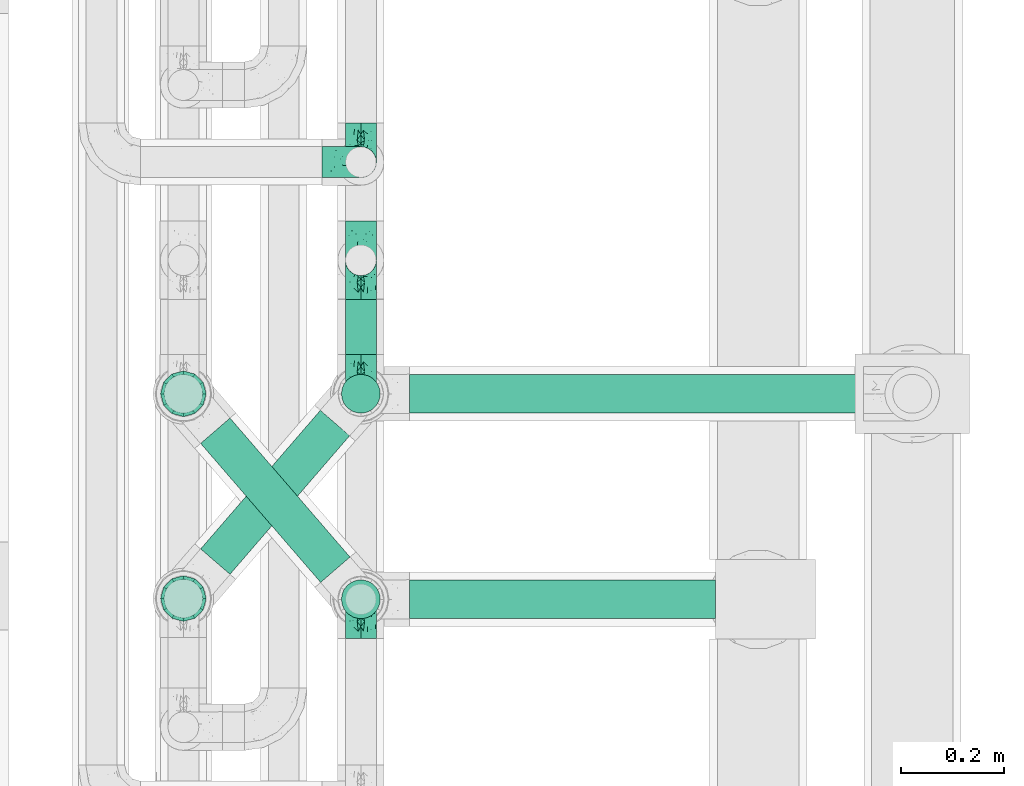
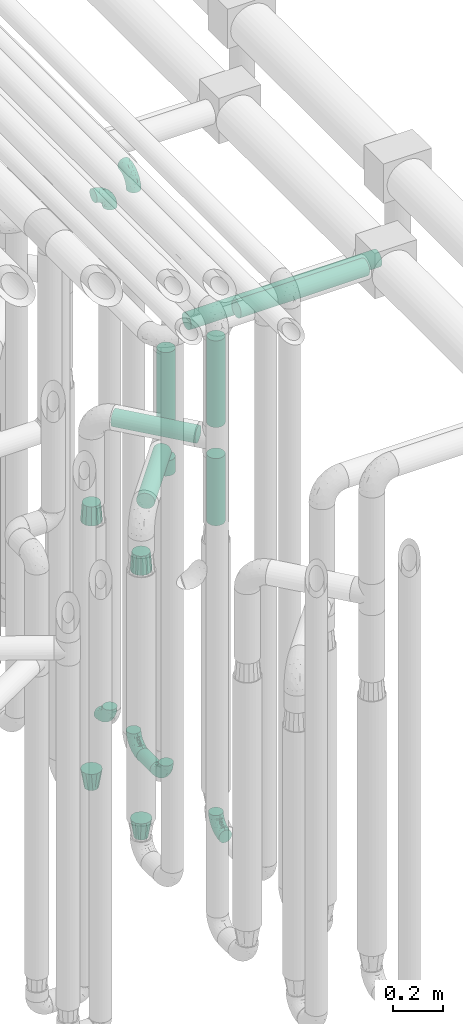
# One storey, part 617 of 827: 10 flow fittings, 9 flow segments.
"""IFC2X3 building model written with IfcOpenShell, lengths in millimetres."""

from ifc_helpers import new_model, entity, si_unit, converted_unit, derived_unit, direction, frame, origin, origin_2d_with_axis, place, context, subcontext, project, spatial, circle, extrude, faceted_brep, source, transform, mapped, material, type_object, type_shapes, element, save


model = new_model("IFC2X3")

# Units and contexts
model_context = context("Model", 3, precision=0.01, world=origin(), true_north=direction((6.12303176911189e-17, 1.0)))
body_context = subcontext(model_context, "Body", "Model", "MODEL_VIEW")
ifc_project = project(units=[si_unit("LENGTHUNIT", "METRE", prefix="MILLI"), si_unit("AREAUNIT", "SQUARE_METRE"), si_unit("VOLUMEUNIT", "CUBIC_METRE"), converted_unit("PLANEANGLEUNIT", "DEGREE", entity("IfcRatioMeasure", 0.0174532925199433), si_unit("PLANEANGLEUNIT", "RADIAN"), dimensions=[0, 0, 0, 0, 0, 0, 0]), si_unit("MASSUNIT", "GRAM", prefix="KILO"), derived_unit("MASSDENSITYUNIT", [(si_unit("MASSUNIT", "GRAM", prefix="KILO"), 1), (si_unit("LENGTHUNIT", "METRE"), -3)]), derived_unit("MOMENTOFINERTIAUNIT", [(si_unit("LENGTHUNIT", "METRE"), 4)]), si_unit("TIMEUNIT", "SECOND"), si_unit("FREQUENCYUNIT", "HERTZ"), si_unit("THERMODYNAMICTEMPERATUREUNIT", "DEGREE_CELSIUS"), derived_unit("THERMALTRANSMITTANCEUNIT", [(si_unit("MASSUNIT", "GRAM", prefix="KILO"), 1), (si_unit("THERMODYNAMICTEMPERATUREUNIT", "KELVIN"), -1), (si_unit("TIMEUNIT", "SECOND"), -3)]), derived_unit("VOLUMETRICFLOWRATEUNIT", [(si_unit("LENGTHUNIT", "METRE"), 3), (si_unit("TIMEUNIT", "SECOND"), -1)]), derived_unit("MASSFLOWRATEUNIT", [(si_unit("MASSUNIT", "GRAM", prefix="KILO"), 1), (si_unit("TIMEUNIT", "SECOND"), -1)]), derived_unit("ROTATIONALFREQUENCYUNIT", [(si_unit("TIMEUNIT", "SECOND"), -1)]), si_unit("ELECTRICCURRENTUNIT", "AMPERE"), si_unit("ELECTRICVOLTAGEUNIT", "VOLT"), si_unit("POWERUNIT", "WATT"), si_unit("FORCEUNIT", "NEWTON", prefix="KILO"), si_unit("ILLUMINANCEUNIT", "LUX"), si_unit("LUMINOUSFLUXUNIT", "LUMEN"), si_unit("LUMINOUSINTENSITYUNIT", "CANDELA"), derived_unit("USERDEFINED", [(si_unit("MASSUNIT", "GRAM", prefix="KILO"), -1), (si_unit("LENGTHUNIT", "METRE"), -2), (si_unit("TIMEUNIT", "SECOND"), 3), (si_unit("LUMINOUSFLUXUNIT", "LUMEN"), 1)]), derived_unit("LINEARVELOCITYUNIT", [(si_unit("LENGTHUNIT", "METRE"), 1), (si_unit("TIMEUNIT", "SECOND"), -1)]), si_unit("PRESSUREUNIT", "PASCAL"), derived_unit("USERDEFINED", [(si_unit("LENGTHUNIT", "METRE"), -2), (si_unit("MASSUNIT", "GRAM", prefix="KILO"), 1), (si_unit("TIMEUNIT", "SECOND"), -2)]), derived_unit("LINEARFORCEUNIT", [(si_unit("MASSUNIT", "GRAM", prefix="KILO"), 1), (si_unit("LENGTHUNIT", "METRE"), 1), (si_unit("TIMEUNIT", "SECOND"), -2), (si_unit("LENGTHUNIT", "METRE"), -1)]), derived_unit("PLANARFORCEUNIT", [(si_unit("MASSUNIT", "GRAM", prefix="KILO"), 1), (si_unit("LENGTHUNIT", "METRE"), 1), (si_unit("TIMEUNIT", "SECOND"), -2), (si_unit("LENGTHUNIT", "METRE"), -2)])], contexts=[model_context])

# Site, building, storey
site_placement = place(None, origin())
site = spatial("IfcSite", under=ifc_project, at=site_placement, CompositionType="ELEMENT")
building_placement = place(site_placement, origin())
building = spatial("IfcBuilding", under=site, at=building_placement, CompositionType="ELEMENT")
storey_placement = place(building_placement, frame((0.0, 0.0, 28200.0)))
storey = spatial("IfcBuildingStorey", under=building, at=storey_placement, Name="08", CompositionType="ELEMENT", Elevation=28200.0)

# Flow segments
pipe_segment_type = type_object("IfcPipeSegmentType", PredefinedType="NOTDEFINED")
flow_segment_1_placement = place(storey_placement, frame((36943.44, 11806.2, 368.4)))
element("IfcFlowSegment", 1, at=flow_segment_1_placement, inside=storey, type_object=pipe_segment_type, context=body_context, shape_type="SweptSolid", body=[
    extrude(circle(Radius=30.0, at=origin_2d_with_axis()), frame((31.6, 0.0, 31.6), z_axis=(0.0, 1.0, 0.0), x_axis=(-1.0, 0.0, 0.0)), (0.0, 0.0, 1.0), 108.000000000017),
])
flow_segment_2_placement = place(storey_placement, frame((36935.69, 11690.86, 2126.0)))
element("IfcFlowSegment", 2, at=flow_segment_2_placement, inside=storey, type_object=pipe_segment_type, context=body_context, shape_type="SweptSolid", body=[
    extrude(circle(Radius=37.75, at=origin_2d_with_axis()), frame((39.35, 39.35, 0.0), z_axis=(0.0, 0.0, 1.0), x_axis=(-1.0, 0.0, 0.0)), (0.0, 0.0, 1.0), 378.999999999992),
])
flow_segment_3_placement = place(storey_placement, frame((37070.03, 11690.86, 2560.65)))
element("IfcFlowSegment", 3, at=flow_segment_3_placement, inside=storey, type_object=pipe_segment_type, context=body_context, shape_type="SweptSolid", body=[
    extrude(circle(Radius=37.75, at=origin_2d_with_axis()), frame((0.0, 39.35, 39.35), z_axis=(1.0, 0.0, 0.0), x_axis=(0.0, -1.0, 0.0)), (0.0, 0.0, 1.0), 883.26568841584),
])
flow_segment_4_placement = place(storey_placement, frame((36935.69, 11290.86, 2381.0)))
element("IfcFlowSegment", 4, at=flow_segment_4_placement, inside=storey, type_object=pipe_segment_type, context=body_context, shape_type="SweptSolid", body=[
    extrude(circle(Radius=37.75, at=origin_2d_with_axis()), frame((39.35, 39.35, 0.0), z_axis=(-3.6642108849416e-08, 1.69450659784675e-07, 1.0), x_axis=(-1.0, 0.0, -3.66421088494165e-08)), (0.0, 0.0, 1.0), 423.9049607946),
])
flow_segment_5_placement = place(storey_placement, frame((37070.03, 11290.86, 2860.56)))
element("IfcFlowSegment", 5, at=flow_segment_5_placement, inside=storey, type_object=pipe_segment_type, context=body_context, shape_type="SweptSolid", body=[
    extrude(circle(Radius=37.75, at=origin_2d_with_axis()), frame((0.0, 39.35, 39.35), z_axis=(1.0, 0.0, 0.0), x_axis=(0.0, 1.0, 0.0)), (0.0, 0.0, 1.0), 595.765249590932),
])
flow_segment_6_placement = place(storey_placement, frame((36661.57, 11361.47, 2265.65)))
element("IfcFlowSegment", 6, at=flow_segment_6_placement, inside=storey, type_object=pipe_segment_type, context=body_context, shape_type="SweptSolid", body=[
    extrude(circle(Radius=37.75, at=origin_2d_with_axis()), frame((30.17, 296.83, 39.35), z_axis=(0.65359148401651, -0.756847522306242, 0.0), x_axis=(-0.756847522306242, -0.65359148401651, 0.0)), (0.0, 0.0, 1.0), 357.482862990724),
])
flow_segment_7_placement = place(storey_placement, frame((36935.69, 11290.86, 1900.0)))
element("IfcFlowSegment", 7, at=flow_segment_7_placement, inside=storey, type_object=pipe_segment_type, context=body_context, shape_type="SweptSolid", body=[
    extrude(circle(Radius=37.75, at=origin_2d_with_axis()), frame((39.35, 39.35, 0.0), z_axis=(0.0, 0.0, 1.0), x_axis=(-1.0, 0.0, 0.0)), (0.0, 0.0, 1.0), 328.999999999994),
])
flow_segment_8_placement = place(storey_placement, frame((36661.57, 11377.22, 2010.65)))
element("IfcFlowSegment", 8, at=flow_segment_8_placement, inside=storey, type_object=pipe_segment_type, context=body_context, shape_type="SweptSolid", body=[
    extrude(circle(Radius=37.75, at=origin_2d_with_axis()), frame((30.17, 26.27, 39.35), z_axis=(0.653617255256319, 0.756825266247894, 0.0), x_axis=(0.756825266247894, -0.653617255256319, 0.0)), (0.0, 0.0, 1.0), 356.436515701913),
])
flow_segment_9_placement = place(storey_placement, frame((36935.69, 11690.86, 1900.0)))
element("IfcFlowSegment", 9, at=flow_segment_9_placement, inside=storey, type_object=pipe_segment_type, context=body_context, shape_type="SweptSolid", body=[
    extrude(circle(Radius=37.75, at=origin_2d_with_axis()), frame((39.35, 39.35, 0.0), z_axis=(0.0, 0.0, 1.0), x_axis=(-1.0, 0.0, 0.0)), (0.0, 0.0, 1.0), 74.0000000000048),
])

# Flow fittings
ifc_material = material()
pipe_fitting_type_1 = type_object("IfcPipeFittingType", Name="ADSK_1", PredefinedType="NOTDEFINED", material=ifc_material)
shared_shape_1 = source(origin(), body_context, "Body", "Brep", [
    faceted_brep([(-76.0, 15.07, -26.11), (-76.0, 7.8, -29.12), (-76.0, 0.0, -30.15), (-76.0, -7.8, -29.12), (-76.0, -15.08, -26.11), (-76.0, -21.32, -21.32), (-76.0, -26.11, -15.08), (-76.0, -29.12, -7.8), (-76.0, -30.15, 0.0), (-76.0, -29.12, 7.8), (-76.0, -26.11, 15.07), (-76.0, -21.32, 21.32), (-76.0, -15.08, 26.11), (-76.0, -7.8, 29.12), (-76.0, 0.0, 30.15), (-76.0, 7.8, 29.12), (-76.0, 15.07, 26.11), (-76.0, 21.32, 21.32), (-76.0, 26.11, 15.07), (-76.0, 29.12, 7.8), (-76.0, 30.15, 0.0), (-76.0, 29.12, -7.8), (-76.0, 26.11, -15.08), (-76.0, 21.32, -21.32), (0.0, 76.0, -30.15), (-7.8, 76.0, -29.12), (-15.07, 76.0, -26.11), (-21.32, 76.0, -21.32), (-26.11, 76.0, -15.08), (-29.12, 76.0, -7.8), (-30.15, 76.0, 0.0), (-29.12, 76.0, 7.8), (-26.11, 76.0, 15.07), (-21.32, 76.0, 21.32), (-15.07, 76.0, 26.11), (-7.8, 76.0, 29.12), (0.0, 76.0, 30.15), (7.8, 76.0, 29.12), (15.08, 76.0, 26.11), (21.32, 76.0, 21.32), (26.11, 76.0, 15.07), (29.12, 76.0, 7.8), (30.15, 76.0, 0.0), (29.12, 76.0, -7.8), (26.11, 76.0, -15.08), (21.32, 76.0, -21.32), (15.08, 76.0, -26.11), (7.8, 76.0, -29.12), (10.79, 31.43, 21.07), (4.32, 31.7, 25.72), (1.65, 15.19, 19.92), (-61.17, -27.8, 0.0), (-51.1, -25.49, 9.84), (-56.14, -10.61, 27.27), (-31.7, -4.32, 25.72), (-39.75, 1.72, 29.41), (-43.2, -24.95, 0.0), (-1.86, 1.86, 0.0), (4.49, 7.65, 5.78), (-7.82, -4.61, 5.83), (-56.21, -22.79, 17.21), (-58.98, -3.38, 29.7), (-53.96, 5.6, 30.07), (-10.86, 10.86, 25.48), (-17.2, -2.6, 20.44), (-49.15, -16.01, 22.7), (-22.18, -14.24, 7.99), (-28.4, -17.42, 0.0), (-13.61, -9.88, 0.0), (-39.0, 23.48, 27.76), (-58.76, 12.54, 28.36), (-41.61, 15.41, 29.48), (16.01, 49.15, 22.7), (-58.55, 25.93, 19.53), (-51.53, 33.5, 13.51), (-64.92, 28.76, 12.4), (-7.48, 23.14, 28.25), (-1.72, 39.75, 29.41), (-12.04, 27.88, 29.88), (-63.91, 18.81, 24.52), (-11.63, 65.16, 28.18), (-4.97, 57.02, 30.05), (9.88, 13.61, 0.0), (-62.5, 31.74, 5.02), (-45.17, 30.98, 21.2), (-21.78, 9.76, 28.58), (10.61, 56.14, 27.27), (-32.09, 54.42, 13.26), (22.79, 56.21, 17.21), (15.38, 31.17, 15.63), (25.49, 51.1, 9.84), (21.84, 36.35, 5.92), (24.95, 43.2, 0.0), (3.38, 58.98, 29.7), (-31.17, -15.38, 15.63), (-39.39, 41.78, 15.45), (-34.56, 41.13, 20.79), (-39.81, -23.25, 5.49), (27.8, 61.17, 0.0), (-31.74, 62.5, 5.02), (-53.07, 36.29, 0.0), (-42.95, 42.95, 7.29), (-36.29, 53.07, 0.0), (-19.83, 58.51, 24.79), (-25.48, 60.2, 19.41), (-14.53, 50.96, 28.57), (-13.31, 37.09, 30.07), (-26.16, 40.06, 26.4), (-32.43, -10.35, 21.9), (17.42, 28.4, 0.0), (14.24, 22.18, 7.99), (-38.67, 9.72, 30.15), (-24.66, 17.36, 30.09), (-37.08, 31.49, 24.99), (-49.27, 22.83, 25.24), (-20.8, 38.81, 28.63), (-27.58, 27.58, 29.2), (-36.07, -20.23, 10.71), (-15.19, -6.16, 14.9), (6.6, 15.4, 14.49), (-2.51, 2.51, 11.35), (-65.16, 11.63, -28.18), (-49.15, -16.01, -22.7), (-57.02, 4.97, -30.05), (-25.93, 58.55, -19.53), (-33.5, 51.53, -13.51), (-28.76, 64.92, -12.4), (-60.2, 25.48, -19.41), (-58.51, 19.83, -24.79), (4.61, 7.82, -5.83), (-7.65, -4.49, -5.78), (-2.51, 2.51, -11.35), (-62.5, 31.74, -5.02), (-50.96, 14.53, -28.57), (-37.09, 13.31, -30.07), (-42.95, 42.95, -7.29), (25.49, 51.1, -9.84), (22.79, 56.21, -17.21), (-40.06, 26.16, -26.4), (3.38, 58.98, -29.7), (-5.6, 53.96, -30.07), (-27.88, 12.04, -29.88), (-9.76, 21.78, -28.58), (-23.14, 7.48, -28.25), (-51.1, -25.49, -9.84), (15.38, 31.17, -15.63), (16.01, 49.15, -22.7), (-23.48, 39.0, -27.76), (-12.54, 58.76, -28.36), (-15.41, 41.61, -29.48), (-56.21, -22.79, -17.21), (-9.72, 38.67, -30.15), (-17.36, 24.66, -30.09), (-22.18, -14.24, -7.99), (-41.13, 34.56, -20.79), (-31.74, 62.5, -5.02), (-58.98, -3.38, -29.7), (-31.17, -15.38, -15.63), (-56.14, -10.61, -27.27), (14.24, 22.18, -7.99), (23.25, 39.81, -5.49), (-31.49, 37.08, -24.99), (-15.19, -6.16, -14.9), (1.65, 15.19, -19.92), (-18.81, 63.91, -24.52), (-32.59, -11.62, -20.84), (-31.7, -4.32, -25.72), (-17.2, -2.6, -20.44), (-39.75, 1.72, -29.41), (-54.42, 32.09, -13.26), (-30.98, 45.17, -21.2), (10.61, 56.14, -27.27), (10.23, 31.31, -21.52), (4.32, 31.7, -25.72), (-41.78, 39.39, -15.45), (-1.72, 39.75, -29.41), (-36.35, -21.84, -5.92), (-22.83, 49.27, -25.24), (-38.81, 20.8, -28.63), (-27.58, 27.58, -29.2), (-10.86, 10.86, -25.48), (20.23, 36.07, -10.71), (6.6, 15.4, -14.49)], [[[0, 1, 2, 3, 4, 5, 6, 7, 8, 9, 10, 11, 12, 13, 14, 15, 16, 17, 18, 19, 20, 21, 22, 23]], [[24, 25, 26, 27, 28, 29, 30, 31, 32, 33, 34, 35, 36, 37, 38, 39, 40, 41, 42, 43, 44, 45, 46, 47]], [[48, 49, 50]], [[51, 52, 9]], [[53, 54, 55]], [[9, 52, 10]], [[56, 52, 51]], [[57, 58, 59]], [[11, 10, 60]], [[14, 61, 62]], [[63, 54, 64]], [[65, 12, 11]], [[65, 53, 12]], [[66, 67, 68]], [[69, 70, 71]], [[72, 39, 38]], [[73, 74, 75]], [[15, 70, 16]], [[76, 77, 78]], [[16, 79, 17]], [[13, 61, 14]], [[35, 80, 81]], [[14, 62, 15]], [[17, 73, 18]], [[57, 82, 58]], [[20, 19, 83]], [[75, 19, 18]], [[70, 15, 62]], [[73, 84, 74]], [[78, 85, 76]], [[38, 86, 72]], [[32, 31, 87]], [[88, 89, 90]], [[91, 92, 90]], [[72, 86, 49]], [[36, 93, 37]], [[75, 83, 19]], [[36, 35, 81]], [[60, 94, 65]], [[40, 90, 41]], [[95, 96, 87]], [[88, 90, 40]], [[66, 97, 67]], [[90, 98, 41]], [[40, 39, 88]], [[99, 31, 30]], [[20, 83, 100]], [[101, 102, 100]], [[52, 60, 10]], [[102, 99, 30]], [[96, 103, 104]], [[83, 101, 100]], [[12, 53, 13]], [[104, 103, 33]], [[105, 106, 81]], [[107, 105, 103]], [[64, 54, 108]], [[80, 103, 105]], [[80, 35, 34]], [[34, 33, 103]], [[86, 38, 37]], [[109, 110, 82]], [[71, 111, 112]], [[69, 107, 113]], [[79, 73, 17]], [[114, 113, 84]], [[33, 32, 104]], [[115, 107, 116]], [[105, 115, 106]], [[93, 81, 77]], [[54, 53, 65]], [[61, 53, 55]], [[108, 94, 64]], [[54, 63, 85]], [[93, 86, 37]], [[77, 76, 49]], [[77, 49, 86]], [[49, 63, 50]], [[60, 52, 117]], [[65, 11, 60]], [[39, 72, 88]], [[89, 88, 72]], [[71, 70, 62]], [[79, 70, 114]], [[103, 96, 107]], [[69, 113, 114]], [[112, 106, 116]], [[77, 81, 106]], [[112, 116, 71]], [[112, 55, 85]], [[64, 50, 63]], [[57, 59, 68]], [[32, 87, 104]], [[96, 104, 87]], [[94, 118, 64]], [[50, 119, 89]], [[50, 64, 118]], [[50, 89, 48]], [[81, 93, 36]], [[86, 93, 77]], [[53, 61, 13]], [[62, 61, 55]], [[71, 62, 111]], [[69, 71, 116]], [[95, 101, 74]], [[99, 101, 87]], [[118, 66, 59]], [[117, 97, 66]], [[117, 66, 94]], [[91, 89, 110]], [[91, 110, 109]], [[110, 89, 119]], [[9, 8, 51]], [[98, 90, 92]], [[98, 42, 41]], [[101, 83, 74]], [[101, 99, 102]], [[87, 31, 99]], [[62, 55, 111]], [[55, 112, 111]], [[107, 69, 116]], [[70, 69, 114]], [[107, 96, 113]], [[84, 113, 96]], [[84, 96, 95]], [[114, 84, 73]], [[70, 79, 16]], [[73, 79, 114]], [[54, 85, 55]], [[76, 85, 63]], [[49, 76, 63]], [[77, 106, 78]], [[106, 112, 78]], [[85, 78, 112]], [[73, 75, 18]], [[83, 75, 74]], [[103, 80, 34]], [[81, 80, 105]], [[101, 95, 87]], [[84, 95, 74]], [[106, 115, 116]], [[105, 107, 115]], [[120, 59, 58]], [[82, 110, 58]], [[119, 58, 110]], [[118, 59, 120]], [[66, 68, 59]], [[54, 65, 108]], [[94, 108, 65]], [[66, 118, 94]], [[50, 118, 120]], [[50, 120, 119]], [[119, 120, 58]], [[89, 72, 48]], [[49, 48, 72]], [[60, 117, 94]], [[117, 52, 97]], [[52, 56, 97]], [[67, 97, 56]], [[92, 91, 109]], [[89, 91, 90]], [[121, 1, 0]], [[122, 5, 4]], [[2, 1, 123]], [[124, 125, 126]], [[127, 128, 23]], [[129, 130, 131]], [[100, 132, 20]], [[133, 134, 123]], [[135, 100, 102]], [[136, 137, 44]], [[133, 128, 138]], [[24, 139, 140]], [[141, 142, 143]], [[121, 128, 133]], [[6, 144, 7]], [[137, 145, 146]], [[144, 51, 7]], [[147, 148, 149]], [[144, 6, 150]], [[149, 151, 152]], [[153, 68, 67]], [[154, 128, 127]], [[30, 155, 102]], [[43, 42, 98]], [[156, 3, 2]], [[157, 144, 150]], [[158, 4, 3]], [[24, 140, 25]], [[155, 135, 102]], [[159, 160, 109]], [[30, 29, 155]], [[147, 138, 161]], [[27, 124, 28]], [[57, 129, 82]], [[162, 163, 131]], [[27, 26, 164]], [[148, 26, 25]], [[165, 166, 167]], [[24, 47, 139]], [[143, 168, 141]], [[22, 21, 169]], [[125, 124, 170]], [[148, 25, 140]], [[46, 146, 171]], [[158, 122, 4]], [[0, 23, 128]], [[1, 121, 123]], [[109, 82, 159]], [[45, 44, 137]], [[146, 46, 45]], [[136, 43, 98]], [[132, 21, 20]], [[136, 98, 92]], [[172, 173, 146]], [[46, 171, 47]], [[43, 136, 44]], [[174, 154, 169]], [[171, 173, 175]], [[6, 5, 150]], [[126, 29, 28]], [[176, 56, 144]], [[122, 158, 166]], [[164, 124, 27]], [[177, 161, 170]], [[23, 22, 127]], [[178, 138, 179]], [[133, 178, 134]], [[156, 123, 168]], [[156, 158, 3]], [[168, 143, 166]], [[168, 166, 158]], [[166, 180, 167]], [[173, 171, 146]], [[139, 171, 175]], [[172, 145, 163]], [[173, 180, 142]], [[5, 122, 150]], [[157, 150, 122]], [[137, 136, 181]], [[146, 45, 137]], [[149, 148, 140]], [[164, 148, 177]], [[128, 154, 138]], [[147, 161, 177]], [[152, 134, 179]], [[168, 123, 134]], [[152, 179, 149]], [[152, 175, 142]], [[57, 130, 129]], [[157, 165, 167]], [[22, 169, 127]], [[154, 127, 169]], [[163, 167, 180]], [[162, 157, 167]], [[173, 163, 180]], [[182, 163, 145]], [[123, 156, 2]], [[158, 156, 168]], [[171, 139, 47]], [[140, 139, 175]], [[149, 140, 151]], [[147, 149, 179]], [[174, 135, 125]], [[132, 135, 169]], [[176, 157, 153]], [[176, 153, 67]], [[153, 157, 162]], [[182, 159, 129]], [[181, 160, 159]], [[181, 159, 145]], [[51, 144, 56]], [[51, 8, 7]], [[135, 132, 100]], [[169, 21, 132]], [[126, 155, 29]], [[135, 155, 125]], [[140, 175, 151]], [[175, 152, 151]], [[138, 147, 179]], [[148, 147, 177]], [[138, 154, 161]], [[170, 161, 154]], [[170, 154, 174]], [[177, 170, 124]], [[148, 164, 26]], [[124, 164, 177]], [[173, 142, 175]], [[143, 142, 180]], [[166, 143, 180]], [[168, 134, 141]], [[134, 152, 141]], [[142, 141, 152]], [[124, 126, 28]], [[155, 126, 125]], [[128, 121, 0]], [[123, 121, 133]], [[135, 174, 169]], [[170, 174, 125]], [[134, 178, 179]], [[133, 138, 178]], [[130, 153, 162]], [[68, 153, 130]], [[57, 68, 130]], [[182, 129, 131]], [[159, 82, 129]], [[157, 122, 165]], [[166, 165, 122]], [[163, 162, 167]], [[162, 131, 130]], [[145, 172, 146]], [[163, 173, 172]], [[159, 182, 145]], [[131, 163, 182]], [[56, 176, 67]], [[157, 176, 144]], [[137, 181, 145]], [[181, 136, 160]], [[136, 92, 160]], [[109, 160, 92]]]),
])
type_shapes(pipe_fitting_type_1, [shared_shape_1])
for number, where, z_axis, x_axis, name in (
    (10, (36975.03, 12181.17, 3000.0), (0.0, 1.0, 0.0), (1.0, 0.0, 0.0), "ADSK_1"),
    (11, (36975.03, 12181.17, 400.0), (1.0, 0.0, 0.0), (0.0, 0.0, -1.0), "ADSK_1"),
    (12, (36975.03, 11330.2, 400.0), (1.0, 0.0, 0.0), (0.0, 1.0, 0.0), "ADSK_1"),
    (13, (36975.03, 11730.2, 400.0), (-1.0, 0.0, 0.0), (0.0, -1.0, 0.0), "ADSK_1"),
    (14, (36975.03, 11990.2, 3200.0), (1.0, 0.0, 0.0), (0.0, -1.0, 0.0), "ADSK_1"),
    (15, (36975.03, 11990.2, 400.0), (1.0, 0.0, 0.0), (0.0, 1.0, 0.0), "ADSK_1"),
):
    element("IfcFlowFitting", number, at=place(storey_placement, frame(where, z_axis=z_axis, x_axis=x_axis)), inside=storey, type_object=pipe_fitting_type_1, material=ifc_material, Name=name, ObjectType="ADSK_1", context=body_context, shape_type="MappedRepresentation", body=[
        mapped(shared_shape_1, transform((0.0, 0.0, 0.0), scale=1.0)),
    ])
pipe_fitting_type_2 = type_object("IfcPipeFittingType", Name="ADSK_1", PredefinedType="NOTDEFINED", material=ifc_material)
shared_shape_2 = source(origin(), body_context, "Body", "Brep", [
    faceted_brep([(89.0, -44.45, 0.0), (89.0, -41.96, -9.31), (89.0, -38.49, -22.22), (89.0, -30.36, -30.36), (89.0, -22.23, -38.49), (89.0, -11.11, -41.47), (89.0, 0.0, -44.45), (89.0, 11.11, -41.47), (89.0, 22.22, -38.49), (89.0, 30.36, -30.36), (89.0, 38.49, -22.22), (89.0, 41.96, -9.31), (89.0, 44.45, 0.0), (89.0, 41.96, 9.31), (89.0, 38.49, 22.23), (89.0, 30.36, 30.36), (89.0, 22.22, 38.49), (89.0, 11.11, 41.47), (89.0, 0.0, 44.45), (89.0, -11.11, 41.47), (89.0, -22.23, 38.49), (89.0, -30.36, 30.36), (89.0, -38.49, 22.23), (89.0, -41.96, 9.31), (0.0, 38.05, 0.0), (0.0, 35.5, -9.51), (0.0, 32.95, -19.02), (0.0, 25.99, -25.99), (0.0, 19.02, -32.95), (0.0, 9.51, -35.5), (0.0, 0.0, -38.05), (0.0, -9.51, -35.5), (0.0, -19.03, -32.95), (0.0, -25.99, -25.99), (0.0, -32.95, -19.02), (0.0, -35.5, -9.51), (0.0, -38.05, 0.0), (0.0, -35.5, 9.51), (0.0, -32.95, 19.03), (0.0, -25.99, 25.99), (0.0, -19.03, 32.95), (0.0, -9.51, 35.5), (0.0, 0.0, 38.05), (0.0, 9.51, 35.5), (0.0, 19.03, 32.95), (0.0, 25.99, 25.99), (0.0, 32.95, 19.03), (0.0, 35.5, 9.51)], [[[0, 1, 2, 3, 4, 5, 6, 7, 8, 9, 10, 11, 12, 13, 14, 15, 16, 17, 18, 19, 20, 21, 22, 23]], [[24, 25, 26, 27, 28, 29, 30, 31, 32, 33, 34, 35, 36, 37, 38, 39, 40, 41, 42, 43, 44, 45, 46, 47]], [[2, 1, 0, 36, 35, 34]], [[28, 8, 7, 6, 30, 29]], [[32, 4, 3, 2, 34, 33]], [[5, 4, 32, 31, 30, 6]], [[10, 26, 25, 24, 12, 11]], [[9, 8, 28, 27, 26, 10]], [[14, 13, 12, 24, 47, 46]], [[40, 20, 19, 18, 42, 41]], [[44, 16, 15, 14, 46, 45]], [[17, 16, 44, 43, 42, 18]], [[22, 38, 37, 36, 0, 23]], [[21, 20, 40, 39, 38, 22]]]),
])
type_shapes(pipe_fitting_type_2, [shared_shape_2])
for number, where, z_axis, x_axis, name in (
    (16, (36629.64, 11730.2, 1870.0), (0.0, 1.0, 0.0), (0.0, 0.0, -1.0), "ADSK_1"),
    (17, (36629.64, 11331.59, 1870.0), (0.0, 1.0, 0.0), (0.0, 0.0, -1.0), "ADSK_1"),
):
    element("IfcFlowFitting", number, at=place(storey_placement, frame(where, z_axis=z_axis, x_axis=x_axis)), inside=storey, type_object=pipe_fitting_type_2, material=ifc_material, Name=name, ObjectType="ADSK_1", context=body_context, shape_type="MappedRepresentation", body=[
        mapped(shared_shape_2, transform((0.0, 0.0, 0.0), scale=1.0)),
    ])
pipe_fitting_type_3 = type_object("IfcPipeFittingType", Name="ADSK_1", PredefinedType="NOTDEFINED", material=ifc_material)
shared_shape_3 = source(origin(), body_context, "Body", "Brep", [
    faceted_brep([(89.0, -44.45, 0.0), (89.0, -42.1, -8.76), (89.0, -38.49, -22.22), (89.0, -30.36, -30.36), (89.0, -22.23, -38.49), (89.0, -11.11, -41.47), (89.0, 0.0, -44.45), (89.0, 11.11, -41.47), (89.0, 22.22, -38.49), (89.0, 30.36, -30.36), (89.0, 38.49, -22.22), (89.0, 42.1, -8.76), (89.0, 44.45, 0.0), (89.0, 42.1, 8.76), (89.0, 38.49, 22.23), (89.0, 30.36, 30.36), (89.0, 22.22, 38.49), (89.0, 11.11, 41.47), (89.0, 0.0, 44.45), (89.0, -11.11, 41.47), (89.0, -22.23, 38.49), (89.0, -30.36, 30.36), (89.0, -38.49, 22.23), (89.0, -42.1, 8.76), (0.0, 30.15, 0.0), (0.0, 27.27, -8.86), (0.0, 24.39, -17.72), (0.0, 16.85, -23.2), (0.0, 9.32, -28.67), (0.0, 0.0, -28.67), (0.0, -9.32, -28.67), (0.0, -16.85, -23.2), (0.0, -24.39, -17.72), (0.0, -27.27, -8.86), (0.0, -30.15, 0.0), (0.0, -27.27, 8.86), (0.0, -24.39, 17.72), (0.0, -16.85, 23.2), (0.0, -9.32, 28.67), (0.0, 0.0, 28.67), (0.0, 9.32, 28.67), (0.0, 16.85, 23.2), (0.0, 24.39, 17.72), (0.0, 27.27, 8.86)], [[[0, 1, 2, 3, 4, 5, 6, 7, 8, 9, 10, 11, 12, 13, 14, 15, 16, 17, 18, 19, 20, 21, 22, 23]], [[24, 25, 26, 27, 28, 29, 30, 31, 32, 33, 34, 35, 36, 37, 38, 39, 40, 41, 42, 43]], [[2, 33, 32]], [[28, 7, 29]], [[29, 5, 30]], [[24, 12, 11]], [[3, 32, 31]], [[34, 1, 0]], [[1, 34, 33]], [[8, 28, 27]], [[2, 1, 33]], [[31, 4, 3]], [[2, 32, 3]], [[11, 25, 24]], [[26, 10, 9]], [[10, 25, 11]], [[28, 8, 7]], [[27, 26, 9]], [[26, 25, 10]], [[31, 30, 4]], [[8, 27, 9]], [[29, 7, 6]], [[5, 29, 6]], [[5, 4, 30]], [[14, 43, 42]], [[38, 19, 39]], [[39, 17, 40]], [[34, 0, 23]], [[15, 42, 41]], [[24, 13, 12]], [[13, 24, 43]], [[20, 38, 37]], [[14, 13, 43]], [[41, 16, 15]], [[14, 42, 15]], [[23, 35, 34]], [[36, 22, 21]], [[22, 35, 23]], [[38, 20, 19]], [[37, 36, 21]], [[36, 35, 22]], [[41, 40, 16]], [[20, 37, 21]], [[39, 19, 18]], [[17, 39, 18]], [[17, 16, 40]]]),
])
type_shapes(pipe_fitting_type_3, [shared_shape_3])
flow_fitting_1_placement = place(storey_placement, frame((36629.64, 11331.59, 476.0), z_axis=(1.0, 0.0, 0.0), x_axis=(0.0, 0.0, 1.0)))
element("IfcFlowFitting", 18, at=flow_fitting_1_placement, inside=storey, type_object=pipe_fitting_type_3, material=ifc_material, Name="ADSK_1", ObjectType="ADSK_1", context=body_context, shape_type="MappedRepresentation", body=[
    mapped(shared_shape_3, transform((0.0, 0.0, 0.0), scale=1.0)),
])
pipe_fitting_type_4 = type_object("IfcPipeFittingType", Name="ADSK_1", PredefinedType="NOTDEFINED", material=ifc_material)
shared_shape_4 = source(origin(), body_context, "Body", "Brep", [
    faceted_brep([(89.0, 38.49, -22.22), (89.0, 42.1, -8.76), (89.0, 44.45, 0.0), (89.0, 42.1, 8.76), (89.0, 38.49, 22.23), (89.0, 30.36, 30.36), (89.0, 22.23, 38.49), (89.0, 11.11, 41.47), (89.0, 0.0, 44.45), (89.0, -11.11, 41.47), (89.0, -22.22, 38.49), (89.0, -30.36, 30.36), (89.0, -38.49, 22.23), (89.0, -42.1, 8.76), (89.0, -44.45, 0.0), (89.0, -42.1, -8.76), (89.0, -38.49, -22.22), (89.0, -30.36, -30.36), (89.0, -22.22, -38.49), (89.0, -11.11, -41.47), (89.0, 0.0, -44.45), (89.0, 11.11, -41.47), (89.0, 22.23, -38.49), (89.0, 30.36, -30.36), (0.0, -24.39, -17.72), (0.0, -27.27, -8.86), (0.0, -30.15, 0.0), (0.0, -27.27, 8.86), (0.0, -24.39, 17.72), (0.0, -16.85, 23.2), (0.0, -9.32, 28.67), (0.0, 0.0, 28.67), (0.0, 9.32, 28.67), (0.0, 16.85, 23.2), (0.0, 24.39, 17.72), (0.0, 27.27, 8.86), (0.0, 30.15, 0.0), (0.0, 27.27, -8.86), (0.0, 24.39, -17.72), (0.0, 16.85, -23.2), (0.0, 9.32, -28.67), (0.0, 0.0, -28.67), (0.0, -9.32, -28.67), (0.0, -16.85, -23.2)], [[[0, 1, 2, 3, 4, 5, 6, 7, 8, 9, 10, 11, 12, 13, 14, 15, 16, 17, 18, 19, 20, 21, 22, 23]], [[24, 25, 26, 27, 28, 29, 30, 31, 32, 33, 34, 35, 36, 37, 38, 39, 40, 41, 42, 43]], [[38, 37, 0]], [[41, 19, 42]], [[40, 21, 41]], [[15, 14, 26]], [[39, 38, 23]], [[2, 1, 36]], [[37, 36, 1]], [[43, 42, 18]], [[37, 1, 0]], [[23, 22, 39]], [[23, 38, 0]], [[26, 25, 15]], [[17, 16, 24]], [[15, 25, 16]], [[19, 18, 42]], [[17, 24, 43]], [[16, 25, 24]], [[22, 40, 39]], [[17, 43, 18]], [[20, 19, 41]], [[20, 41, 21]], [[40, 22, 21]], [[28, 27, 12]], [[31, 7, 32]], [[30, 9, 31]], [[3, 2, 36]], [[29, 28, 11]], [[14, 13, 26]], [[27, 26, 13]], [[33, 32, 6]], [[27, 13, 12]], [[11, 10, 29]], [[11, 28, 12]], [[36, 35, 3]], [[5, 4, 34]], [[3, 35, 4]], [[7, 6, 32]], [[5, 34, 33]], [[4, 35, 34]], [[10, 30, 29]], [[5, 33, 6]], [[8, 7, 31]], [[8, 31, 9]], [[30, 10, 9]]]),
])
type_shapes(pipe_fitting_type_4, [shared_shape_4])
flow_fitting_2_placement = place(storey_placement, frame((36629.64, 11730.2, 476.0), z_axis=(0.0, 1.0, 0.0), x_axis=(0.0, 0.0, 1.0)))
element("IfcFlowFitting", 19, at=flow_fitting_2_placement, inside=storey, type_object=pipe_fitting_type_4, material=ifc_material, Name="ADSK_1", ObjectType="ADSK_1", context=body_context, shape_type="MappedRepresentation", body=[
    mapped(shared_shape_4, transform((0.0, 0.0, 0.0), scale=1.0)),
])

save(model, "model.ifc")
